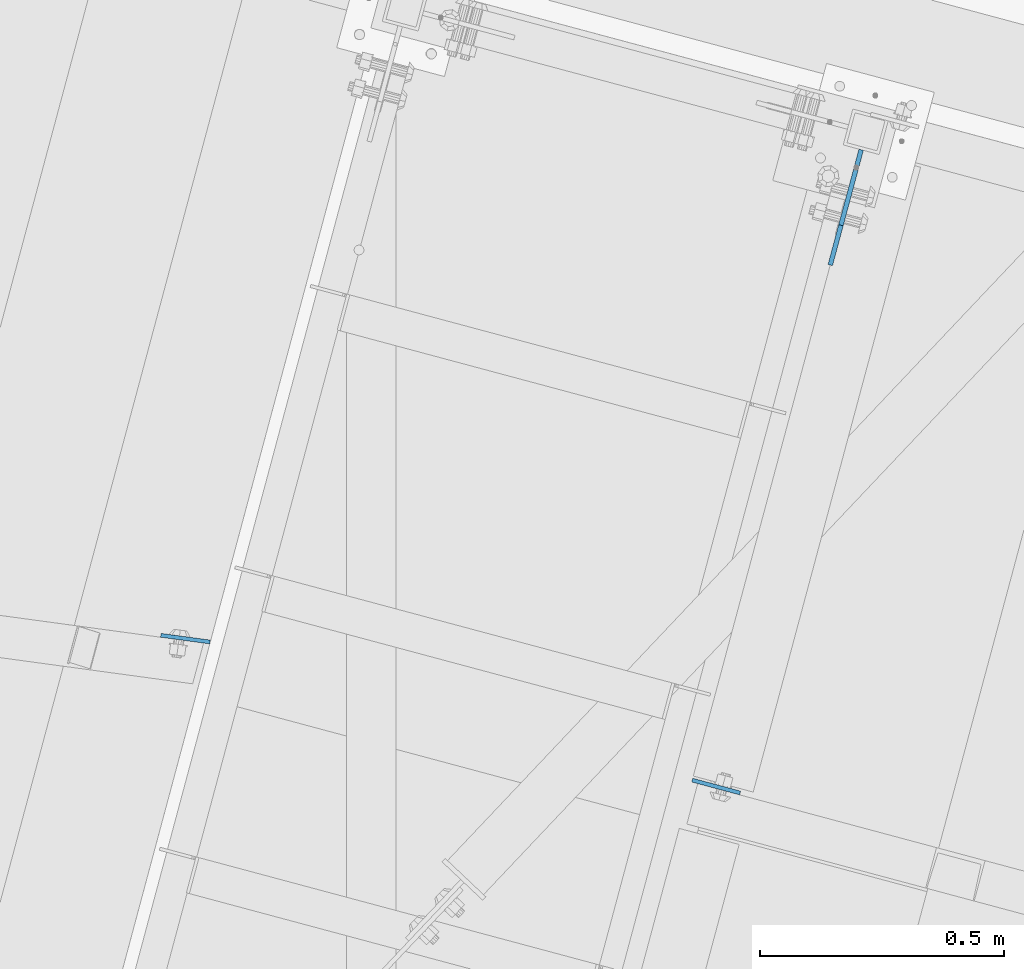
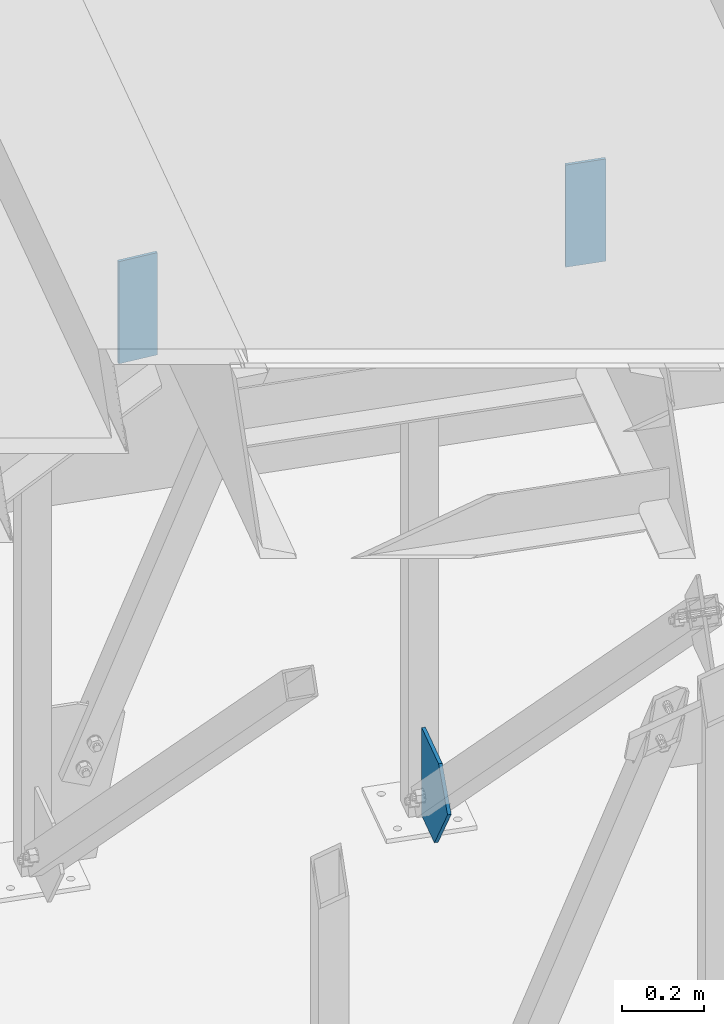
# One storey, part 1692 of 1763: 3 plates, 2 elements without a shape of their own.
"""IFC2X3 building model written with IfcOpenShell, lengths in millimetres."""

from ifc_helpers import new_model, si_unit, frame, origin_with_axes, place, context, subcontext, project, spatial, faceted_brep, material, type_object, element, aggregate, save


model = new_model("IFC2X3")

# Units and contexts
model_context = context("Model", 3, precision=1e-05, world=origin_with_axes())
body_context = subcontext(model_context, "Body", "Model", "MODEL_VIEW")
ifc_project = project(units=[si_unit("LENGTHUNIT", "METRE", prefix="MILLI"), si_unit("AREAUNIT", "SQUARE_METRE"), si_unit("VOLUMEUNIT", "CUBIC_METRE"), si_unit("MASSUNIT", "GRAM", prefix="KILO"), si_unit("TIMEUNIT", "SECOND"), si_unit("PLANEANGLEUNIT", "RADIAN"), si_unit("SOLIDANGLEUNIT", "STERADIAN"), si_unit("THERMODYNAMICTEMPERATUREUNIT", "DEGREE_CELSIUS"), si_unit("LUMINOUSINTENSITYUNIT", "LUMEN")], contexts=[model_context])

# Site, building, storey
site_placement = place(None, origin_with_axes())
site = spatial("IfcSite", under=ifc_project, at=site_placement, CompositionType="ELEMENT")
building_placement = place(site_placement, origin_with_axes())
building = spatial("IfcBuilding", under=site, at=building_placement, Name="Undefined", CompositionType="ELEMENT")
storey_placement = place(building_placement, origin_with_axes())
storey = spatial("IfcBuildingStorey", under=building, at=storey_placement, Name="Undefined", CompositionType="ELEMENT", Elevation=0.0)

# Assembly, plates
assembly_1_placement = place(storey_placement, origin_with_axes())
assembly_1 = element("IfcElementAssembly", 1, at=assembly_1_placement, inside=storey, Name="FRAME", AssemblyPlace="NOTDEFINED", PredefinedType="RIGID_FRAME")
ifc_material = material(Name="STEEL/A36")
plate_type_1 = type_object("IfcPlateType", PredefinedType="NOTDEFINED")
plate_1_placement = place(assembly_1_placement, frame((-27031.3214096986, 61669.8233166382, 2590.80000074404), z_axis=(0.965913267114843, -0.258865912030785, 0.0), x_axis=(0.0, 0.0, -1.0)))
plate_1 = element("IfcPlate", 2, at=plate_1_placement, type_object=plate_type_1, material=ifc_material, Name="PLATE", context=body_context, shape_type="Brep", body=[
    faceted_brep([(0.0, -3.96900000000096, 0.0), (-1.18234311230481e-11, -3.96900000000096, 101.599998474121), (-1.18234311230481e-11, 3.96900000000096, 101.599998474121), (0.0, 3.96900000000096, 0.0), (304.799987792969, -3.96900000000096, 101.599998474121), (304.799987792969, 3.96900000000096, 101.599998474121), (304.799987792969, -3.96900000000096, -3.63797880709171e-11), (304.799987792969, 3.96900000000096, -3.63797880709171e-11)], [[[0, 1, 2, 3]], [[1, 4, 5, 2]], [[4, 6, 7, 5]], [[6, 0, 3, 7]], [[5, 7, 3, 2]], [[6, 4, 1, 0]]]),
])
plate_type_2 = type_object("IfcPlateType", PredefinedType="NOTDEFINED")
plate_2_placement = place(assembly_1_placement, frame((-28019.3377285891, 61952.8892196144, 2504.06869434076), z_axis=(-0.990886745556476, 0.134697651939721, -6.5132187760355e-06), x_axis=(1.15139999949278e-05, 4.29629999941661e-05, -0.999999999010804)))
plate_2 = element("IfcPlate", 3, at=plate_2_placement, type_object=plate_type_2, material=ifc_material, Name="PLATE", context=body_context, shape_type="Brep", body=[
    faceted_brep([(0.0, -3.96900000000096, 0.0), (-1.77351466845721e-11, -3.96900000009191, 101.702690124672), (-1.72803993336856e-11, 3.96899999988091, 101.702690124686), (0.0, 3.96900000000096, 0.0), (304.799987792996, -3.96900000059395, 101.702690124985), (304.799987792996, 3.96899999937887, 101.702690124999), (304.799987792969, -3.96900000000096, -3.63797880709171e-11), (304.799987792969, 3.96900000000096, -3.63797880709171e-11)], [[[0, 1, 2, 3]], [[1, 4, 5, 2]], [[4, 6, 7, 5]], [[6, 0, 3, 7]], [[5, 7, 3, 2]], [[6, 4, 1, 0]]]),
])
aggregate(assembly_1, [plate_1, plate_2])

# Assembly, plate
assembly_2_placement = place(storey_placement, origin_with_axes())
assembly_2 = element("IfcElementAssembly", 4, at=assembly_2_placement, inside=storey, Name="COLUMN", AssemblyPlace="NOTDEFINED", PredefinedType="RIGID_FRAME")
plate_type_3 = type_object("IfcPlateType", PredefinedType="NOTDEFINED")
plate_3_placement = place(assembly_2_placement, frame((-26685.1200624452, 62961.5047351356, -254.000000000131), z_axis=(-0.258865912030778, -0.965913267114844, 3.00823476209188e-08), x_axis=(0.0, 0.0, 1.0)))
plate_3 = element("IfcPlate", 5, at=plate_3_placement, type_object=plate_type_3, material=ifc_material, Name="PLATE", context=body_context, shape_type="Brep", body=[
    faceted_brep([(0.0, -4.76249999999982, 0.0), (3.8198777474463e-11, -4.76249999978609, 120.649999999834), (3.45607986673713e-11, 4.76250000024447, 120.649999999841), (0.0, 4.76249999999982, 0.0), (167.223571777343, -4.76250000003347, 244.65702819838), (167.223571777342, 4.76249999996799, 244.657028198359), (261.979339599607, -4.76250000033906, 160.097076416292), (261.979339599607, 4.76249999965512, 160.097076416285), (261.979339599606, -4.76250000055734, 3.20142135024071e-10), (261.979339599606, 4.76249999944412, 3.20142135024071e-10)], [[[0, 1, 2, 3]], [[1, 4, 5, 2]], [[4, 6, 7, 5]], [[6, 8, 9, 7]], [[8, 0, 3, 9]], [[5, 7, 9, 3, 2]], [[8, 6, 4, 1, 0]]]),
])
aggregate(assembly_2, [plate_3])

save(model, "model.ifc")
